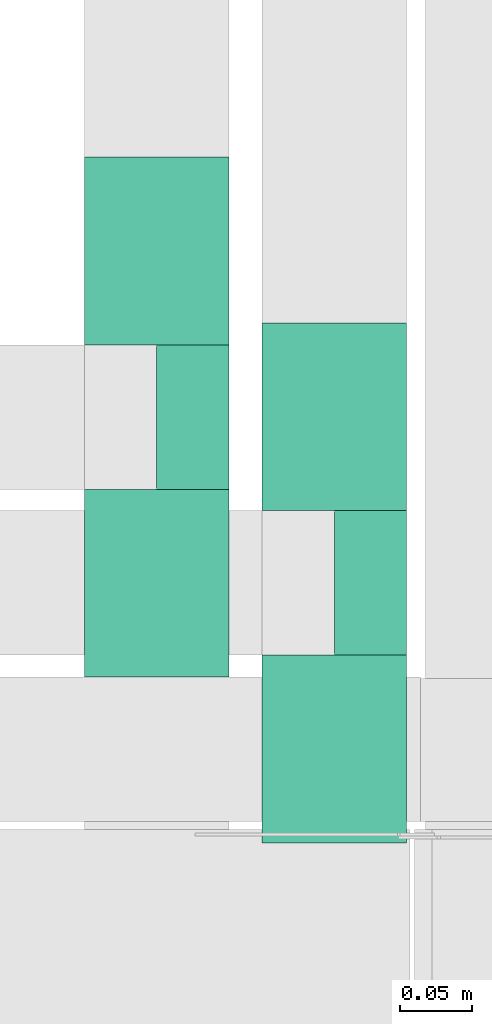
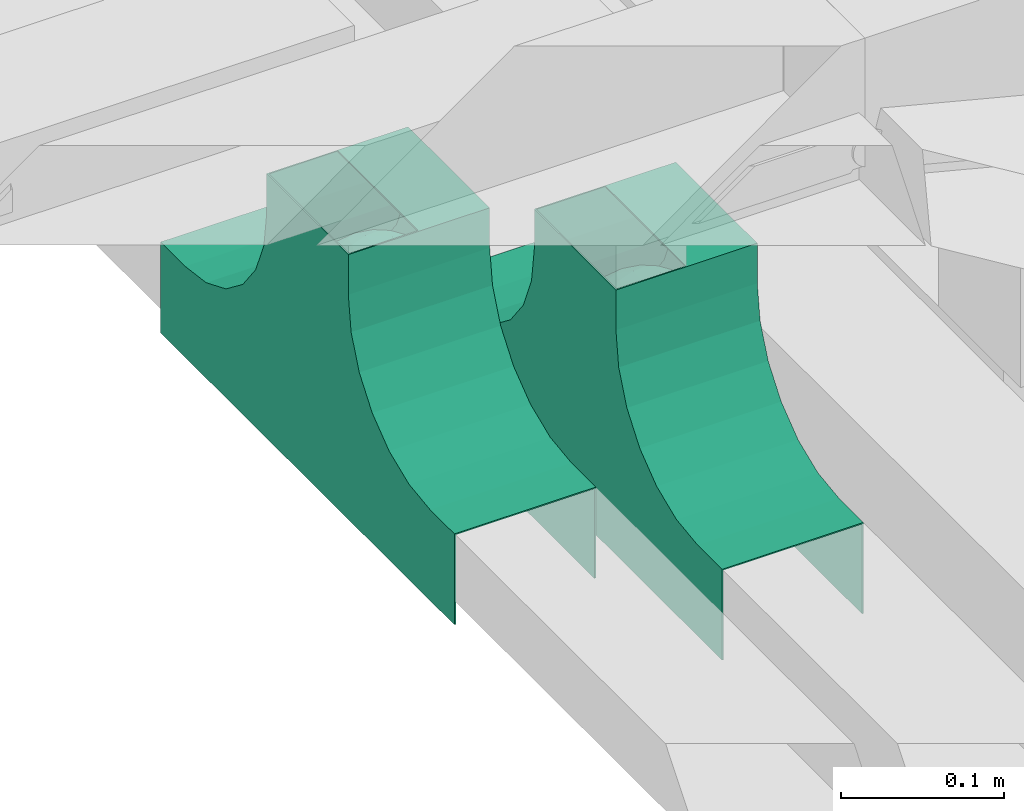
# One storey, part 6 of 19: 2 flow fittings.
"""IFC2X3 building model written with IfcOpenShell, lengths in millimetres."""

from ifc_helpers import new_model, entity, si_unit, converted_unit, derived_unit, direction, frame, origin, place, context, subcontext, project, spatial, faceted_brep, source, transform, mapped, material, material_list, type_object, type_shapes, element, save


model = new_model("IFC2X3")

# Units and contexts
model_context = context("Model", 3, precision=0.01, world=origin(), true_north=direction((6.12303176911189e-17, 1.0)))
body_context = subcontext(model_context, "Body", "Model", "MODEL_VIEW")
ifc_project = project(units=[si_unit("LENGTHUNIT", "METRE", prefix="MILLI"), si_unit("AREAUNIT", "SQUARE_METRE"), si_unit("VOLUMEUNIT", "CUBIC_METRE"), converted_unit("PLANEANGLEUNIT", "DEGREE", entity("IfcRatioMeasure", 0.0174532925199433), si_unit("PLANEANGLEUNIT", "RADIAN"), dimensions=[0, 0, 0, 0, 0, 0, 0]), si_unit("MASSUNIT", "GRAM", prefix="KILO"), derived_unit("MASSDENSITYUNIT", [(si_unit("MASSUNIT", "GRAM", prefix="KILO"), 1), (si_unit("LENGTHUNIT", "METRE"), -3)]), derived_unit("MOMENTOFINERTIAUNIT", [(si_unit("LENGTHUNIT", "METRE"), 4)]), si_unit("TIMEUNIT", "SECOND"), si_unit("FREQUENCYUNIT", "HERTZ"), si_unit("THERMODYNAMICTEMPERATUREUNIT", "DEGREE_CELSIUS"), derived_unit("THERMALTRANSMITTANCEUNIT", [(si_unit("MASSUNIT", "GRAM", prefix="KILO"), 1), (si_unit("THERMODYNAMICTEMPERATUREUNIT", "KELVIN"), -1), (si_unit("TIMEUNIT", "SECOND"), -3)]), derived_unit("VOLUMETRICFLOWRATEUNIT", [(si_unit("LENGTHUNIT", "METRE"), 3), (si_unit("TIMEUNIT", "SECOND"), -1)]), derived_unit("MASSFLOWRATEUNIT", [(si_unit("MASSUNIT", "GRAM", prefix="KILO"), 1), (si_unit("TIMEUNIT", "SECOND"), -1)]), derived_unit("ROTATIONALFREQUENCYUNIT", [(si_unit("TIMEUNIT", "SECOND"), -1)]), si_unit("ELECTRICCURRENTUNIT", "AMPERE"), si_unit("ELECTRICVOLTAGEUNIT", "VOLT"), si_unit("POWERUNIT", "WATT"), si_unit("FORCEUNIT", "NEWTON", prefix="KILO"), si_unit("ILLUMINANCEUNIT", "LUX"), si_unit("LUMINOUSFLUXUNIT", "LUMEN"), si_unit("LUMINOUSINTENSITYUNIT", "CANDELA"), derived_unit("USERDEFINED", [(si_unit("MASSUNIT", "GRAM", prefix="KILO"), -1), (si_unit("LENGTHUNIT", "METRE"), -2), (si_unit("TIMEUNIT", "SECOND"), 3), (si_unit("LUMINOUSFLUXUNIT", "LUMEN"), 1)]), derived_unit("LINEARVELOCITYUNIT", [(si_unit("LENGTHUNIT", "METRE"), 1), (si_unit("TIMEUNIT", "SECOND"), -1)]), si_unit("PRESSUREUNIT", "PASCAL"), derived_unit("USERDEFINED", [(si_unit("LENGTHUNIT", "METRE"), -2), (si_unit("MASSUNIT", "GRAM", prefix="KILO"), 1), (si_unit("TIMEUNIT", "SECOND"), -2)]), derived_unit("LINEARFORCEUNIT", [(si_unit("MASSUNIT", "GRAM", prefix="KILO"), 1), (si_unit("LENGTHUNIT", "METRE"), 1), (si_unit("TIMEUNIT", "SECOND"), -2), (si_unit("LENGTHUNIT", "METRE"), -1)]), derived_unit("PLANARFORCEUNIT", [(si_unit("MASSUNIT", "GRAM", prefix="KILO"), 1), (si_unit("LENGTHUNIT", "METRE"), 1), (si_unit("TIMEUNIT", "SECOND"), -2), (si_unit("LENGTHUNIT", "METRE"), -2)])], contexts=[model_context])

# Site, building, storey
site_placement = place(None, origin())
site = spatial("IfcSite", under=ifc_project, at=site_placement, CompositionType="ELEMENT")
building_placement = place(site_placement, origin())
building = spatial("IfcBuilding", under=site, at=building_placement, CompositionType="ELEMENT")
storey_placement = place(building_placement, frame((0.0, 0.0, 12000.0)))
storey = spatial("IfcBuildingStorey", under=building, at=storey_placement, CompositionType="ELEMENT", Elevation=12000.0)

# Flow fittings
ifc_material_1 = material()
ifc_material_2 = material()
ifc_material_list = material_list([ifc_material_1, ifc_material_2])
cable_carrier_fitting_type = type_object("IfcCableCarrierFittingType", Name="470_DKC_S5_TSS cover (flat)", PredefinedType="NOTDEFINED", material=ifc_material_1)
shared_shape = source(origin(), body_context, "Body", "Brep", [
    faceted_brep([(43.65, -13.62, 44.78), (44.77, 0.0, 42.74), (48.26, -5.6, 53.19), (16.66, 5.33, 18.16), (11.56, -8.33, 17.07), (2.02, 2.7, 15.11), (-7.81, -35.95, 31.14), (-17.21, -38.27, 37.81), (-11.13, -27.32, 24.63), (37.7, -7.25, 32.97), (10.64, 26.52, 23.97), (19.21, 19.84, 23.32), (10.42, 17.81, 19.46), (48.75, 0.0, 65.0), (48.07, 6.52, 52.87), (-37.46, 12.16, 34.19), (-31.35, 12.15, 27.99), (-38.09, 3.52, 32.8), (48.75, 11.13, 65.0), (9.67, 42.57, 40.61), (17.48, 37.97, 37.57), (8.35, 35.36, 30.65), (36.7, 20.43, 37.88), (28.22, 12.58, 25.69), (28.4, 24.01, 31.57), (37.1, 7.75, 32.39), (30.39, 38.11, 65.0), (34.74, 34.64, 65.0), (32.94, 32.13, 45.44), (26.04, 41.58, 65.0), (-44.77, 0.0, 42.74), (-35.92, -8.72, 31.33), (-42.7, -12.19, 42.01), (5.42, -48.76, 65.0), (0.0, -48.78, 54.04), (7.59, -47.43, 51.12), (34.0, -31.65, 46.49), (40.01, -26.24, 50.49), (30.39, -38.11, 65.0), (-47.55, -8.65, 52.2), (43.92, -21.15, 65.0), (-47.55, 8.68, 52.19), (-43.92, 21.15, 65.0), (-41.56, 23.54, 50.22), (-36.7, 20.43, 37.88), (-42.68, 12.16, 41.97), (-0.04, -44.68, 42.56), (43.35, 13.13, 43.81), (-9.67, -42.82, 41.06), (2.93, -38.3, 33.0), (10.58, -32.36, 28.38), (17.48, -37.97, 37.57), (29.42, -14.29, 27.18), (29.26, 0.0, 24.46), (-34.74, 34.64, 65.0), (-35.59, 30.87, 48.26), (16.27, 46.29, 65.0), (15.4, 45.37, 50.7), (10.85, 47.52, 65.0), (-22.09, 42.26, 49.96), (-16.27, 46.29, 65.0), (-15.4, 45.37, 50.7), (-35.57, -30.88, 48.24), (-34.74, -34.64, 65.0), (-41.54, -23.57, 50.22), (-21.2, -29.91, 31.0), (-22.09, -42.26, 49.96), (-28.59, -35.77, 44.93), (27.97, -26.92, 33.49), (26.56, -36.75, 43.94), (-4.7, -12.82, 16.9), (-3.71, -22.05, 20.28), (0.0, -29.85, 24.89), (-8.78, 23.47, 21.73), (-10.71, 12.15, 17.7), (-19.19, 19.81, 23.29), (19.21, -19.84, 23.32), (10.27, -43.25, 42.12), (-16.27, -46.29, 65.0), (-15.42, -45.43, 50.92), (-10.85, -47.52, 65.0), (-21.69, -45.05, 65.0), (-26.04, -41.58, 65.0), (-30.39, -38.11, 65.0), (-26.91, -11.71, 24.52), (-28.57, -22.53, 30.71), (-14.35, 0.55, 17.11), (20.39, 29.7, 30.33), (25.88, 35.56, 41.22), (-1.9, 38.3, 32.91), (-0.04, 44.68, 42.56), (-9.54, 42.67, 40.74), (-10.12, 33.04, 28.86), (-17.21, 38.27, 37.81), (-28.59, 35.77, 44.93), (-30.39, 38.11, 65.0), (-26.04, 41.58, 65.0), (-21.69, 45.05, 65.0), (0.92, 16.99, 17.99), (0.0, 29.85, 24.89), (-28.43, 23.64, 31.34), (22.08, -42.72, 51.3), (0.0, -50.0, 65.0), (-7.98, 47.29, 50.85), (-10.85, 47.52, 65.0), (-5.42, 48.76, 65.0), (-39.09, -31.17, 65.0), (-36.7, -20.43, 37.88), (-20.05, 29.88, 30.29), (48.75, -11.13, 65.0), (36.7, -20.43, 37.88), (39.09, -31.17, 65.0), (43.92, 21.15, 65.0), (41.04, 24.48, 50.28), (21.43, -9.87, 20.92), (19.85, -30.3, 30.53), (26.04, -41.58, 65.0), (8.28, -22.62, 21.18), (-19.19, -19.81, 23.29), (-17.56, -9.66, 19.19), (-29.26, 0.0, 24.46), (-22.28, 8.45, 21.04), (21.69, -45.05, 65.0), (-7.75, -47.32, 50.85), (22.09, 42.36, 50.25), (21.69, 45.05, 65.0), (7.94, 47.25, 50.71), (5.42, 48.76, 65.0), (-43.92, -21.15, 65.0), (-39.09, 31.17, 65.0), (-48.75, 11.13, 65.0), (-48.75, -11.13, 65.0), (-48.75, 0.0, 65.0), (0.0, 50.0, 65.0), (0.0, 48.77, 53.96), (-5.42, -48.76, 65.0), (16.27, -46.29, 65.0), (10.85, -47.52, 65.0), (39.09, 31.17, 65.0), (34.74, -34.64, 65.0), (-43.65, -13.62, 85.22), (-44.77, 0.0, 87.26), (-48.26, -5.6, 76.81), (-16.66, 5.33, 111.84), (-11.56, -8.33, 112.93), (-2.02, 2.7, 114.89), (7.81, -35.95, 98.86), (17.21, -38.27, 92.19), (11.13, -27.32, 105.37), (-37.7, -7.25, 97.03), (-10.64, 26.52, 106.03), (-19.21, 19.84, 106.68), (-10.42, 17.81, 110.54), (-48.07, 6.52, 77.13), (37.46, 12.16, 95.81), (31.35, 12.15, 102.01), (38.09, 3.52, 97.2), (-9.67, 42.57, 89.39), (-17.48, 37.97, 92.43), (-8.35, 35.36, 99.35), (-36.7, 20.43, 92.12), (-28.22, 12.58, 104.31), (-28.4, 24.01, 98.43), (-37.1, 7.75, 97.61), (-32.94, 32.13, 84.56), (44.77, 0.0, 87.26), (35.92, -8.72, 98.67), (42.7, -12.19, 87.99), (0.0, -48.78, 75.96), (-7.59, -47.43, 78.88), (-34.0, -31.65, 83.51), (-40.01, -26.24, 79.51), (47.55, -8.65, 77.8), (47.55, 8.68, 77.81), (41.56, 23.54, 79.78), (36.7, 20.43, 92.12), (42.68, 12.16, 88.03), (0.04, -44.68, 87.44), (-43.35, 13.13, 86.19), (9.67, -42.82, 88.94), (-2.93, -38.3, 97.0), (-10.58, -32.36, 101.62), (-17.48, -37.97, 92.43), (-29.42, -14.29, 102.82), (-29.26, 0.0, 105.54), (35.59, 30.87, 81.74), (-15.4, 45.37, 79.3), (22.09, 42.26, 80.04), (15.4, 45.37, 79.3), (35.57, -30.88, 81.76), (41.54, -23.57, 79.78), (21.2, -29.91, 99.0), (22.09, -42.26, 80.04), (28.59, -35.77, 85.07), (-27.97, -26.92, 96.51), (-26.56, -36.75, 86.06), (4.7, -12.82, 113.1), (3.71, -22.05, 109.72), (0.0, -29.85, 105.11), (8.78, 23.47, 108.27), (10.71, 12.15, 112.3), (19.19, 19.81, 106.71), (-19.21, -19.84, 106.68), (-10.27, -43.25, 87.88), (15.42, -45.43, 79.08), (26.91, -11.71, 105.48), (28.57, -22.53, 99.29), (14.35, 0.55, 112.89), (-20.39, 29.7, 99.67), (-25.88, 35.56, 88.78), (1.9, 38.3, 97.09), (0.04, 44.68, 87.44), (9.54, 42.67, 89.26), (10.12, 33.04, 101.14), (17.21, 38.27, 92.19), (28.59, 35.77, 85.07), (-0.92, 16.99, 112.01), (0.0, 29.85, 105.11), (28.43, 23.64, 98.66), (-22.08, -42.72, 78.7), (7.98, 47.29, 79.15), (36.7, -20.43, 92.12), (20.05, 29.88, 99.71), (-36.7, -20.43, 92.12), (-41.04, 24.48, 79.72), (-21.43, -9.87, 109.08), (-19.85, -30.3, 99.47), (-8.28, -22.62, 108.82), (19.19, -19.81, 106.71), (17.56, -9.66, 110.81), (29.26, 0.0, 105.54), (22.28, 8.45, 108.96), (7.75, -47.32, 79.15), (-22.09, 42.36, 79.75), (-7.94, 47.25, 79.29), (0.0, 48.77, 76.04)], [[[0, 1, 2]], [[3, 4, 5]], [[6, 7, 8]], [[1, 0, 9]], [[10, 11, 12]], [[13, 2, 14]], [[15, 16, 17]], [[14, 18, 13]], [[19, 20, 21]], [[22, 23, 24]], [[1, 9, 25]], [[26, 27, 28, 29]], [[30, 31, 32]], [[33, 34, 35]], [[36, 37, 38]], [[32, 39, 30]], [[2, 40, 0]], [[23, 22, 25]], [[41, 42, 43]], [[44, 15, 45]], [[46, 35, 34]], [[25, 22, 47]], [[31, 30, 17]], [[48, 49, 46]], [[50, 51, 49]], [[52, 53, 9]], [[43, 54, 55]], [[56, 57, 58]], [[59, 60, 61]], [[62, 63, 64]], [[8, 7, 65]], [[7, 66, 67]], [[68, 36, 69]], [[70, 5, 4]], [[8, 71, 72]], [[73, 74, 75]], [[68, 76, 52]], [[77, 46, 49]], [[78, 79, 80]], [[7, 6, 48]], [[67, 81, 82, 83]], [[84, 85, 31]], [[85, 65, 67]], [[70, 86, 5]], [[23, 3, 11]], [[21, 87, 10]], [[21, 20, 87]], [[28, 24, 88]], [[19, 89, 90]], [[91, 90, 89]], [[91, 92, 93]], [[94, 95, 96, 97]], [[98, 99, 10]], [[100, 16, 44]], [[77, 51, 101]], [[33, 102, 34]], [[103, 91, 61]], [[93, 59, 61]], [[104, 105, 103]], [[106, 64, 63]], [[107, 31, 85]], [[100, 94, 108]], [[108, 93, 92]], [[43, 55, 44]], [[0, 40, 37]], [[2, 13, 109]], [[2, 1, 14]], [[110, 9, 0]], [[2, 109, 40]], [[37, 40, 111]], [[47, 14, 1]], [[112, 14, 47]], [[113, 112, 47]], [[112, 18, 14]], [[47, 22, 113]], [[52, 9, 110]], [[53, 25, 9]], [[25, 47, 1]], [[23, 25, 53]], [[68, 52, 110]], [[76, 4, 114]], [[51, 115, 69]], [[50, 115, 51]], [[110, 36, 68]], [[3, 23, 53]], [[23, 11, 24]], [[52, 76, 114]], [[98, 12, 5]], [[11, 87, 24]], [[24, 28, 22]], [[87, 88, 24]], [[36, 116, 69]], [[28, 27, 113]], [[114, 3, 53]], [[76, 115, 117]], [[70, 4, 117]], [[118, 84, 119]], [[119, 70, 118]], [[120, 16, 121]], [[37, 36, 110]], [[116, 36, 38]], [[116, 122, 69]], [[34, 123, 46]], [[10, 87, 11]], [[87, 20, 88]], [[12, 98, 10]], [[10, 99, 21]], [[74, 5, 86]], [[73, 75, 108]], [[124, 56, 125]], [[124, 29, 88]], [[89, 21, 99]], [[21, 89, 19]], [[92, 89, 99]], [[89, 92, 91]], [[126, 127, 58]], [[88, 29, 28]], [[20, 57, 124]], [[88, 20, 124]], [[57, 20, 19]], [[73, 92, 99]], [[92, 73, 108]], [[99, 98, 73]], [[74, 86, 121]], [[73, 98, 74]], [[5, 74, 98]], [[100, 108, 75]], [[94, 93, 108]], [[86, 120, 121]], [[100, 44, 55]], [[75, 16, 100]], [[17, 16, 120]], [[31, 17, 120]], [[17, 30, 45]], [[84, 31, 120]], [[31, 107, 32]], [[41, 45, 30]], [[43, 44, 45]], [[107, 64, 32]], [[39, 64, 128]], [[30, 39, 41]], [[129, 43, 42]], [[41, 130, 42]], [[43, 45, 41]], [[62, 83, 63]], [[95, 94, 55]], [[100, 55, 94]], [[64, 107, 62]], [[131, 39, 128]], [[64, 106, 128]], [[85, 62, 107]], [[67, 83, 62]], [[39, 32, 64]], [[130, 41, 132]], [[59, 97, 60]], [[133, 127, 134]], [[59, 94, 97]], [[104, 61, 60]], [[94, 59, 93]], [[126, 134, 127]], [[126, 58, 57]], [[19, 90, 126]], [[134, 105, 133]], [[126, 90, 134]], [[103, 90, 91]], [[105, 134, 103]], [[90, 103, 134]], [[119, 120, 86]], [[84, 118, 85]], [[65, 85, 118]], [[62, 85, 67]], [[8, 65, 118]], [[67, 65, 7]], [[71, 118, 70]], [[8, 72, 6]], [[49, 6, 72]], [[6, 49, 48]], [[50, 49, 72]], [[77, 49, 51]], [[101, 69, 122]], [[123, 34, 135]], [[101, 122, 136]], [[137, 77, 136]], [[78, 81, 66]], [[7, 79, 66]], [[67, 66, 81]], [[79, 7, 48]], [[35, 137, 33]], [[123, 80, 79]], [[135, 34, 102]], [[35, 46, 77]], [[80, 123, 135]], [[46, 123, 48]], [[117, 50, 72]], [[115, 76, 68]], [[117, 72, 71]], [[4, 76, 117]], [[39, 132, 41]], [[39, 131, 132]], [[137, 35, 77]], [[124, 57, 56]], [[126, 57, 19]], [[103, 61, 104]], [[61, 91, 93]], [[77, 101, 136]], [[51, 69, 101]], [[28, 113, 22]], [[112, 113, 138]], [[16, 75, 121]], [[74, 121, 75]], [[66, 79, 78]], [[123, 79, 48]], [[0, 37, 110]], [[37, 111, 139, 38]], [[29, 124, 125]], [[115, 50, 117]], [[69, 115, 68]], [[120, 119, 84]], [[70, 119, 86]], [[11, 3, 12]], [[5, 12, 3]], [[118, 71, 8]], [[117, 71, 70]], [[3, 114, 4]], [[53, 52, 114]], [[27, 138, 113]], [[45, 15, 17]], [[44, 16, 15]], [[55, 54, 95]], [[43, 129, 54]], [[140, 141, 142]], [[143, 144, 145]], [[146, 147, 148]], [[141, 140, 149]], [[150, 151, 152]], [[132, 142, 153]], [[154, 155, 156]], [[153, 130, 132]], [[157, 158, 159]], [[160, 161, 162]], [[141, 149, 163]], [[95, 54, 164, 96]], [[165, 166, 167]], [[135, 168, 169]], [[170, 171, 83]], [[167, 172, 165]], [[142, 141, 153]], [[161, 160, 163]], [[173, 112, 174]], [[175, 154, 176]], [[177, 169, 168]], [[163, 160, 178]], [[166, 165, 156]], [[179, 180, 177]], [[181, 182, 180]], [[183, 184, 149]], [[174, 27, 185]], [[60, 186, 104]], [[187, 56, 188]], [[189, 139, 190]], [[148, 147, 191]], [[147, 192, 193]], [[194, 170, 195]], [[196, 145, 144]], [[148, 197, 198]], [[199, 200, 201]], [[194, 202, 183]], [[203, 177, 180]], [[136, 204, 137]], [[147, 146, 179]], [[193, 122, 116, 38]], [[205, 206, 166]], [[206, 191, 193]], [[196, 207, 145]], [[161, 143, 151]], [[159, 208, 150]], [[159, 158, 208]], [[164, 162, 209]], [[157, 210, 211]], [[212, 211, 210]], [[212, 213, 214]], [[215, 26, 29, 125]], [[216, 217, 150]], [[218, 155, 175]], [[203, 182, 219]], [[135, 102, 168]], [[220, 212, 188]], [[214, 187, 188]], [[58, 127, 220]], [[111, 190, 139]], [[221, 166, 206]], [[218, 215, 222]], [[222, 214, 213]], [[174, 185, 175]], [[171, 140, 128]], [[132, 131, 142]], [[142, 128, 140]], [[223, 149, 140]], [[142, 131, 128]], [[171, 128, 106]], [[178, 153, 141]], [[42, 153, 178]], [[224, 42, 178]], [[42, 130, 153]], [[178, 160, 224]], [[183, 149, 223]], [[184, 163, 149]], [[163, 178, 141]], [[161, 163, 184]], [[194, 183, 223]], [[202, 144, 225]], [[182, 226, 195]], [[181, 226, 182]], [[223, 170, 194]], [[143, 161, 184]], [[161, 151, 162]], [[183, 202, 225]], [[216, 152, 145]], [[151, 208, 162]], [[162, 164, 160]], [[208, 209, 162]], [[170, 82, 195]], [[164, 54, 224]], [[225, 143, 184]], [[202, 226, 227]], [[196, 144, 227]], [[228, 205, 229]], [[229, 196, 228]], [[230, 155, 231]], [[171, 170, 223]], [[82, 170, 83]], [[82, 81, 195]], [[168, 232, 177]], [[150, 208, 151]], [[208, 158, 209]], [[152, 216, 150]], [[150, 217, 159]], [[200, 145, 207]], [[199, 201, 222]], [[233, 60, 97]], [[233, 96, 209]], [[210, 159, 217]], [[159, 210, 157]], [[213, 210, 217]], [[210, 213, 212]], [[234, 105, 104]], [[209, 96, 164]], [[158, 186, 233]], [[209, 158, 233]], [[186, 158, 157]], [[199, 213, 217]], [[213, 199, 222]], [[217, 216, 199]], [[200, 207, 231]], [[199, 216, 200]], [[145, 200, 216]], [[218, 222, 201]], [[215, 214, 222]], [[207, 230, 231]], [[218, 175, 185]], [[201, 155, 218]], [[156, 155, 230]], [[166, 156, 230]], [[156, 165, 176]], [[205, 166, 230]], [[166, 221, 167]], [[173, 176, 165]], [[174, 175, 176]], [[221, 190, 167]], [[172, 190, 40]], [[165, 172, 173]], [[138, 174, 112]], [[173, 18, 112]], [[174, 176, 173]], [[189, 38, 139]], [[26, 215, 185]], [[218, 185, 215]], [[190, 221, 189]], [[109, 172, 40]], [[190, 111, 40]], [[206, 189, 221]], [[193, 38, 189]], [[172, 167, 190]], [[18, 173, 13]], [[187, 125, 56]], [[133, 105, 235]], [[187, 215, 125]], [[58, 188, 56]], [[215, 187, 214]], [[234, 235, 105]], [[234, 104, 186]], [[157, 211, 234]], [[235, 127, 133]], [[234, 211, 235]], [[220, 211, 212]], [[127, 235, 220]], [[211, 220, 235]], [[229, 230, 207]], [[205, 228, 206]], [[191, 206, 228]], [[189, 206, 193]], [[148, 191, 228]], [[193, 191, 147]], [[197, 228, 196]], [[148, 198, 146]], [[180, 146, 198]], [[146, 180, 179]], [[181, 180, 198]], [[203, 180, 182]], [[219, 195, 81]], [[232, 168, 33]], [[219, 81, 78]], [[80, 203, 78]], [[136, 122, 192]], [[147, 204, 192]], [[193, 192, 122]], [[204, 147, 179]], [[169, 80, 135]], [[232, 137, 204]], [[33, 168, 102]], [[169, 177, 203]], [[137, 232, 33]], [[177, 232, 179]], [[227, 181, 198]], [[226, 202, 194]], [[227, 198, 197]], [[144, 202, 227]], [[172, 13, 173]], [[172, 109, 13]], [[80, 169, 203]], [[233, 186, 60]], [[234, 186, 157]], [[220, 188, 58]], [[188, 212, 214]], [[203, 219, 78]], [[182, 195, 219]], [[164, 224, 160]], [[42, 224, 129]], [[155, 201, 231]], [[200, 231, 201]], [[192, 204, 136]], [[232, 204, 179]], [[140, 171, 223]], [[171, 106, 63, 83]], [[96, 233, 97]], [[226, 181, 227]], [[195, 226, 194]], [[230, 229, 205]], [[196, 229, 207]], [[151, 143, 152]], [[145, 152, 143]], [[228, 197, 148]], [[227, 197, 196]], [[143, 225, 144]], [[184, 183, 225]], [[54, 129, 224]], [[176, 154, 156]], [[175, 155, 154]], [[185, 27, 26]], [[174, 138, 27]]]),
    faceted_brep([(-50.0, -50.0, 155.0), (50.0, -50.0, 155.0), (50.0, 0.0, 155.0), (-50.0, 0.0, 155.0), (-50.0, -50.0, 154.0), (-50.0, 0.0, 154.0), (50.0, 0.0, 154.0), (50.0, -50.0, 154.0)], [[[0, 1, 2, 3]], [[4, 5, 6, 7]], [[1, 0, 4, 7]], [[2, 1, 7, 6]], [[3, 2, 6, 5]], [[0, 3, 5, 4]]]),
    faceted_brep([(124.12, -50.0, 28.41), (100.0, -50.0, 38.4), (79.29, -50.0, 54.29), (63.4, -50.0, 75.0), (53.41, -50.0, 99.12), (50.0, -50.0, 125.0), (50.0, -50.0, 155.0), (49.0, -50.0, 155.0), (49.0, -50.0, 125.0), (52.44, -50.0, 98.86), (62.53, -50.0, 74.5), (78.58, -50.0, 53.58), (99.5, -50.0, 37.53), (123.86, -50.0, 27.44), (150.0, -50.0, 24.0), (180.0, -50.0, 24.0), (180.0, -50.0, 25.0), (150.0, -50.0, 25.0), (49.0, 50.0, 125.0), (49.0, 50.0, 155.0), (50.0, 50.0, 155.0), (50.0, 50.0, 125.0), (53.41, 50.0, 99.12), (63.4, 50.0, 75.0), (79.29, 50.0, 54.29), (100.0, 50.0, 38.4), (124.12, 50.0, 28.41), (150.0, 50.0, 25.0), (180.0, 50.0, 25.0), (180.0, 50.0, 24.0), (150.0, 50.0, 24.0), (123.86, 50.0, 27.44), (99.5, 50.0, 37.53), (78.58, 50.0, 53.58), (62.53, 50.0, 74.5), (52.44, 50.0, 98.86)], [[[0, 1, 2, 3, 4, 5, 6, 7, 8, 9, 10, 11, 12, 13, 14, 15, 16, 17]], [[18, 19, 20, 21, 22, 23, 24, 25, 26, 27, 28, 29, 30, 31, 32, 33, 34, 35]], [[7, 6, 20, 19]], [[8, 7, 19, 18]], [[9, 35, 34, 10]], [[10, 34, 33, 11]], [[18, 35, 9, 8]], [[12, 32, 31, 13]], [[13, 31, 30, 14]], [[11, 33, 32, 12]], [[15, 14, 30, 29]], [[16, 15, 29, 28]], [[17, 16, 28, 27]], [[0, 17, 27, 26]], [[1, 0, 26, 25]], [[25, 24, 2, 1]], [[4, 3, 23, 22]], [[5, 4, 22, 21]], [[24, 23, 3, 2]], [[6, 5, 21, 20]]]),
    faceted_brep([(-53.41, -50.0, 99.12), (-63.4, -50.0, 75.0), (-79.29, -50.0, 54.29), (-100.0, -50.0, 38.4), (-124.12, -50.0, 28.41), (-150.0, -50.0, 25.0), (-180.0, -50.0, 25.0), (-180.0, -50.0, 24.0), (-150.0, -50.0, 24.0), (-123.86, -50.0, 27.44), (-99.5, -50.0, 37.53), (-78.58, -50.0, 53.58), (-62.53, -50.0, 74.5), (-52.44, -50.0, 98.86), (-49.0, -50.0, 125.0), (-49.0, -50.0, 155.0), (-50.0, -50.0, 155.0), (-50.0, -50.0, 125.0), (-150.0, 50.0, 24.0), (-180.0, 50.0, 24.0), (-180.0, 50.0, 25.0), (-150.0, 50.0, 25.0), (-124.12, 50.0, 28.41), (-100.0, 50.0, 38.4), (-79.29, 50.0, 54.29), (-63.4, 50.0, 75.0), (-53.41, 50.0, 99.12), (-50.0, 50.0, 125.0), (-50.0, 50.0, 155.0), (-49.0, 50.0, 155.0), (-49.0, 50.0, 125.0), (-52.44, 50.0, 98.86), (-62.53, 50.0, 74.5), (-78.58, 50.0, 53.58), (-99.5, 50.0, 37.53), (-123.86, 50.0, 27.44)], [[[0, 1, 2, 3, 4, 5, 6, 7, 8, 9, 10, 11, 12, 13, 14, 15, 16, 17]], [[18, 19, 20, 21, 22, 23, 24, 25, 26, 27, 28, 29, 30, 31, 32, 33, 34, 35]], [[17, 16, 28, 27]], [[0, 17, 27, 26]], [[1, 0, 26, 25]], [[25, 24, 2, 1]], [[4, 3, 23, 22]], [[5, 4, 22, 21]], [[24, 23, 3, 2]], [[6, 5, 21, 20]], [[7, 6, 20, 19]], [[8, 7, 19, 18]], [[9, 35, 34, 10]], [[10, 34, 33, 11]], [[18, 35, 9, 8]], [[12, 32, 31, 13]], [[13, 31, 30, 14]], [[11, 33, 32, 12]], [[15, 14, 30, 29]], [[16, 15, 29, 28]]]),
    faceted_brep([(-50.0, -50.0, 155.0), (-50.0, -50.0, 125.0), (-50.71, -50.0, 119.61), (-51.42, -50.0, 114.21), (-51.92, -50.0, 110.44), (-52.41, -50.0, 106.67), (-52.91, -50.0, 102.89), (-53.41, -50.0, 99.12), (-55.9, -50.0, 93.09), (-58.4, -50.0, 87.06), (-60.9, -50.0, 81.03), (-63.4, -50.0, 75.0), (-67.37, -50.0, 69.82), (-71.34, -50.0, 64.64), (-75.32, -50.0, 59.47), (-79.29, -50.0, 54.29), (-84.47, -50.0, 50.32), (-89.64, -50.0, 46.34), (-94.82, -50.0, 42.37), (-100.0, -50.0, 38.4), (-106.03, -50.0, 35.9), (-112.06, -50.0, 33.4), (-118.09, -50.0, 30.9), (-124.12, -50.0, 28.41), (-130.59, -50.0, 27.56), (-137.06, -50.0, 26.7), (-143.53, -50.0, 25.85), (-150.0, -50.0, 25.0), (-180.0, -50.0, 25.0), (-180.0, -50.0, -43.0), (180.0, -50.0, -43.0), (180.0, -50.0, 25.0), (150.0, -50.0, 25.0), (144.61, -50.0, 25.71), (139.21, -50.0, 26.42), (135.44, -50.0, 26.92), (131.67, -50.0, 27.41), (127.89, -50.0, 27.91), (124.12, -50.0, 28.41), (118.09, -50.0, 30.9), (112.06, -50.0, 33.4), (106.03, -50.0, 35.9), (100.0, -50.0, 38.4), (94.82, -50.0, 42.37), (89.64, -50.0, 46.34), (84.47, -50.0, 50.32), (79.29, -50.0, 54.29), (75.32, -50.0, 59.47), (71.34, -50.0, 64.64), (67.37, -50.0, 69.82), (63.4, -50.0, 75.0), (60.9, -50.0, 81.03), (58.4, -50.0, 87.06), (55.9, -50.0, 93.09), (53.41, -50.0, 99.12), (52.56, -50.0, 105.59), (51.7, -50.0, 112.06), (50.85, -50.0, 118.53), (50.0, -50.0, 125.0), (50.0, -50.0, 155.0), (-180.0, -49.0, -43.0), (-180.0, -49.0, 25.0), (-150.0, -49.0, 25.0), (-144.61, -49.0, 25.71), (-139.21, -49.0, 26.42), (-135.44, -49.0, 26.92), (-131.67, -49.0, 27.41), (-127.89, -49.0, 27.91), (-124.12, -49.0, 28.41), (-118.09, -49.0, 30.9), (-112.06, -49.0, 33.4), (-106.03, -49.0, 35.9), (-100.0, -49.0, 38.4), (-94.82, -49.0, 42.37), (-89.64, -49.0, 46.34), (-84.47, -49.0, 50.32), (-79.29, -49.0, 54.29), (-75.32, -49.0, 59.47), (-71.34, -49.0, 64.64), (-67.37, -49.0, 69.82), (-63.4, -49.0, 75.0), (-60.9, -49.0, 81.03), (-58.4, -49.0, 87.06), (-55.9, -49.0, 93.09), (-53.41, -49.0, 99.12), (-52.56, -49.0, 105.59), (-51.7, -49.0, 112.06), (-50.85, -49.0, 118.53), (-50.0, -49.0, 125.0), (-50.0, -49.0, 155.0), (50.0, -49.0, 155.0), (50.0, -49.0, 125.0), (50.71, -49.0, 119.61), (51.21, -49.0, 115.83), (51.7, -49.0, 112.06), (52.56, -49.0, 105.59), (53.41, -49.0, 99.12), (55.9, -49.0, 93.09), (58.4, -49.0, 87.06), (60.9, -49.0, 81.03), (63.4, -49.0, 75.0), (67.37, -49.0, 69.82), (71.34, -49.0, 64.64), (75.32, -49.0, 59.47), (79.29, -49.0, 54.29), (84.47, -49.0, 50.32), (89.64, -49.0, 46.34), (94.82, -49.0, 42.37), (100.0, -49.0, 38.4), (106.03, -49.0, 35.9), (112.06, -49.0, 33.4), (118.09, -49.0, 30.9), (124.12, -49.0, 28.41), (130.59, -49.0, 27.56), (137.06, -49.0, 26.7), (143.53, -49.0, 25.85), (150.0, -49.0, 25.0), (180.0, -49.0, 25.0), (180.0, -49.0, -43.0)], [[[0, 1, 2, 3, 4, 5, 6, 7, 8, 9, 10, 11, 12, 13, 14, 15, 16, 17, 18, 19, 20, 21, 22, 23, 24, 25, 26, 27, 28, 29, 30, 31, 32, 33, 34, 35, 36, 37, 38, 39, 40, 41, 42, 43, 44, 45, 46, 47, 48, 49, 50, 51, 52, 53, 54, 55, 56, 57, 58, 59]], [[60, 61, 62, 63, 64, 65, 66, 67, 68, 69, 70, 71, 72, 73, 74, 75, 76, 77, 78, 79, 80, 81, 82, 83, 84, 85, 86, 87, 88, 89, 90, 91, 92, 93, 94, 95, 96, 97, 98, 99, 100, 101, 102, 103, 104, 105, 106, 107, 108, 109, 110, 111, 112, 113, 114, 115, 116, 117, 118]], [[1, 0, 89, 88]], [[85, 84, 7, 6, 5, 4, 3, 2, 1, 88, 87, 86]], [[69, 68, 23, 22, 21, 20, 19, 72, 71, 70]], [[76, 15, 14, 13, 12, 11, 80, 79, 78, 77]], [[10, 9, 8, 7, 84, 83, 82, 81, 80, 11]], [[62, 27, 26, 25, 24, 23, 68, 67, 66, 65, 64, 63]], [[15, 76, 75, 74, 73, 72, 19, 18, 17, 16]], [[28, 27, 62, 61]], [[32, 31, 117, 116]], [[29, 28, 61, 60]], [[30, 29, 60, 118]], [[31, 30, 118, 117]], [[113, 112, 38, 37, 36, 35, 34, 33, 32, 116, 115, 114]], [[92, 91, 58, 57, 56, 55, 54, 96, 95, 94, 93]], [[104, 46, 45, 44, 43, 42, 108, 107, 106, 105]], [[108, 42, 41, 40, 39, 38, 112, 111, 110, 109]], [[96, 54, 53, 52, 51, 50, 100, 99, 98, 97]], [[46, 104, 103, 102, 101, 100, 50, 49, 48, 47]], [[59, 58, 91, 90]], [[0, 59, 90, 89]]]),
    faceted_brep([(-79.29, 49.0, 54.29), (-84.47, 49.0, 50.32), (-89.64, 49.0, 46.34), (-94.82, 49.0, 42.37), (-100.0, 49.0, 38.4), (-106.03, 49.0, 35.9), (-112.06, 49.0, 33.4), (-118.09, 49.0, 30.9), (-124.12, 49.0, 28.41), (-130.59, 49.0, 27.56), (-137.06, 49.0, 26.7), (-143.53, 49.0, 25.85), (-150.0, 49.0, 25.0), (-180.0, 49.0, 25.0), (-180.0, 49.0, -43.0), (180.0, 49.0, -43.0), (180.0, 49.0, 25.0), (150.0, 49.0, 25.0), (144.61, 49.0, 25.71), (139.21, 49.0, 26.42), (135.44, 49.0, 26.92), (131.67, 49.0, 27.41), (127.89, 49.0, 27.91), (124.12, 49.0, 28.41), (118.09, 49.0, 30.9), (112.06, 49.0, 33.4), (106.03, 49.0, 35.9), (100.0, 49.0, 38.4), (94.82, 49.0, 42.37), (89.64, 49.0, 46.34), (84.47, 49.0, 50.32), (79.29, 49.0, 54.29), (75.32, 49.0, 59.47), (71.34, 49.0, 64.64), (67.37, 49.0, 69.82), (63.4, 49.0, 75.0), (60.9, 49.0, 81.03), (58.4, 49.0, 87.06), (55.9, 49.0, 93.09), (53.41, 49.0, 99.12), (52.56, 49.0, 105.59), (51.7, 49.0, 112.06), (50.85, 49.0, 118.53), (50.0, 49.0, 125.0), (50.0, 49.0, 155.0), (-50.0, 49.0, 155.0), (-50.0, 49.0, 125.0), (-50.71, 49.0, 119.61), (-51.42, 49.0, 114.21), (-51.92, 49.0, 110.44), (-52.41, 49.0, 106.67), (-52.91, 49.0, 102.89), (-53.41, 49.0, 99.12), (-55.9, 49.0, 93.09), (-58.4, 49.0, 87.06), (-60.9, 49.0, 81.03), (-63.4, 49.0, 75.0), (-67.37, 49.0, 69.82), (-71.34, 49.0, 64.64), (-75.32, 49.0, 59.47), (79.29, 50.0, 54.29), (84.47, 50.0, 50.32), (89.64, 50.0, 46.34), (94.82, 50.0, 42.37), (100.0, 50.0, 38.4), (106.03, 50.0, 35.9), (112.06, 50.0, 33.4), (118.09, 50.0, 30.9), (124.12, 50.0, 28.41), (130.59, 50.0, 27.56), (137.06, 50.0, 26.7), (143.53, 50.0, 25.85), (150.0, 50.0, 25.0), (180.0, 50.0, 25.0), (180.0, 50.0, -43.0), (-180.0, 50.0, -43.0), (-180.0, 50.0, 25.0), (-150.0, 50.0, 25.0), (-144.61, 50.0, 25.71), (-139.21, 50.0, 26.42), (-135.44, 50.0, 26.92), (-131.67, 50.0, 27.41), (-127.89, 50.0, 27.91), (-124.12, 50.0, 28.41), (-118.09, 50.0, 30.9), (-112.06, 50.0, 33.4), (-106.03, 50.0, 35.9), (-100.0, 50.0, 38.4), (-94.82, 50.0, 42.37), (-89.64, 50.0, 46.34), (-84.47, 50.0, 50.32), (-79.29, 50.0, 54.29), (-75.32, 50.0, 59.47), (-71.34, 50.0, 64.64), (-67.37, 50.0, 69.82), (-63.4, 50.0, 75.0), (-60.9, 50.0, 81.03), (-58.4, 50.0, 87.06), (-55.9, 50.0, 93.09), (-53.41, 50.0, 99.12), (-52.56, 50.0, 105.59), (-51.7, 50.0, 112.06), (-50.85, 50.0, 118.53), (-50.0, 50.0, 125.0), (-50.0, 50.0, 155.0), (50.0, 50.0, 155.0), (50.0, 50.0, 125.0), (50.71, 50.0, 119.61), (51.21, 50.0, 115.83), (51.7, 50.0, 112.06), (52.56, 50.0, 105.59), (53.41, 50.0, 99.12), (55.9, 50.0, 93.09), (58.4, 50.0, 87.06), (60.9, 50.0, 81.03), (63.4, 50.0, 75.0), (67.37, 50.0, 69.82), (71.34, 50.0, 64.64), (75.32, 50.0, 59.47)], [[[0, 1, 2, 3, 4, 5, 6, 7, 8, 9, 10, 11, 12, 13, 14, 15, 16, 17, 18, 19, 20, 21, 22, 23, 24, 25, 26, 27, 28, 29, 30, 31, 32, 33, 34, 35, 36, 37, 38, 39, 40, 41, 42, 43, 44, 45, 46, 47, 48, 49, 50, 51, 52, 53, 54, 55, 56, 57, 58, 59]], [[60, 61, 62, 63, 64, 65, 66, 67, 68, 69, 70, 71, 72, 73, 74, 75, 76, 77, 78, 79, 80, 81, 82, 83, 84, 85, 86, 87, 88, 89, 90, 91, 92, 93, 94, 95, 96, 97, 98, 99, 100, 101, 102, 103, 104, 105, 106, 107, 108, 109, 110, 111, 112, 113, 114, 115, 116, 117, 118]], [[13, 12, 77, 76]], [[17, 16, 73, 72]], [[14, 13, 76, 75]], [[15, 14, 75, 74]], [[16, 15, 74, 73]], [[69, 68, 23, 22, 21, 20, 19, 18, 17, 72, 71, 70]], [[107, 106, 43, 42, 41, 40, 39, 111, 110, 109, 108]], [[60, 31, 30, 29, 28, 27, 64, 63, 62, 61]], [[64, 27, 26, 25, 24, 23, 68, 67, 66, 65]], [[111, 39, 38, 37, 36, 35, 115, 114, 113, 112]], [[31, 60, 118, 117, 116, 115, 35, 34, 33, 32]], [[44, 43, 106, 105]], [[45, 44, 105, 104]], [[46, 45, 104, 103]], [[100, 99, 52, 51, 50, 49, 48, 47, 46, 103, 102, 101]], [[84, 83, 8, 7, 6, 5, 4, 87, 86, 85]], [[91, 0, 59, 58, 57, 56, 95, 94, 93, 92]], [[55, 54, 53, 52, 99, 98, 97, 96, 95, 56]], [[77, 12, 11, 10, 9, 8, 83, 82, 81, 80, 79, 78]], [[0, 91, 90, 89, 88, 87, 4, 3, 2, 1]]]),
])
type_shapes(cable_carrier_fitting_type, [shared_shape])
for number, where, z_axis, x_axis, name in (
    (1, (17500.8, 12929.44, 2525.0), (0.0, 0.0, 1.0), (0.0, 1.0, 0.0), "470_DKC_S5_cover (flat)"),
    (2, (17377.76, 13044.16, 2525.0), (0.0, 0.0, 1.0), (0.0, 1.0, 0.0), "470_DKC_S5_cover (flat)"),
):
    element("IfcFlowFitting", number, at=place(storey_placement, frame(where, z_axis=z_axis, x_axis=x_axis)), inside=storey, type_object=cable_carrier_fitting_type, material=ifc_material_list, Name=name, ObjectType="470_DKC_S5_TSS cover (flat)", context=body_context, shape_type="MappedRepresentation", body=[
        mapped(shared_shape, transform((0.0, 0.0, 0.0), scale=1.0)),
    ])

save(model, "model.ifc")
